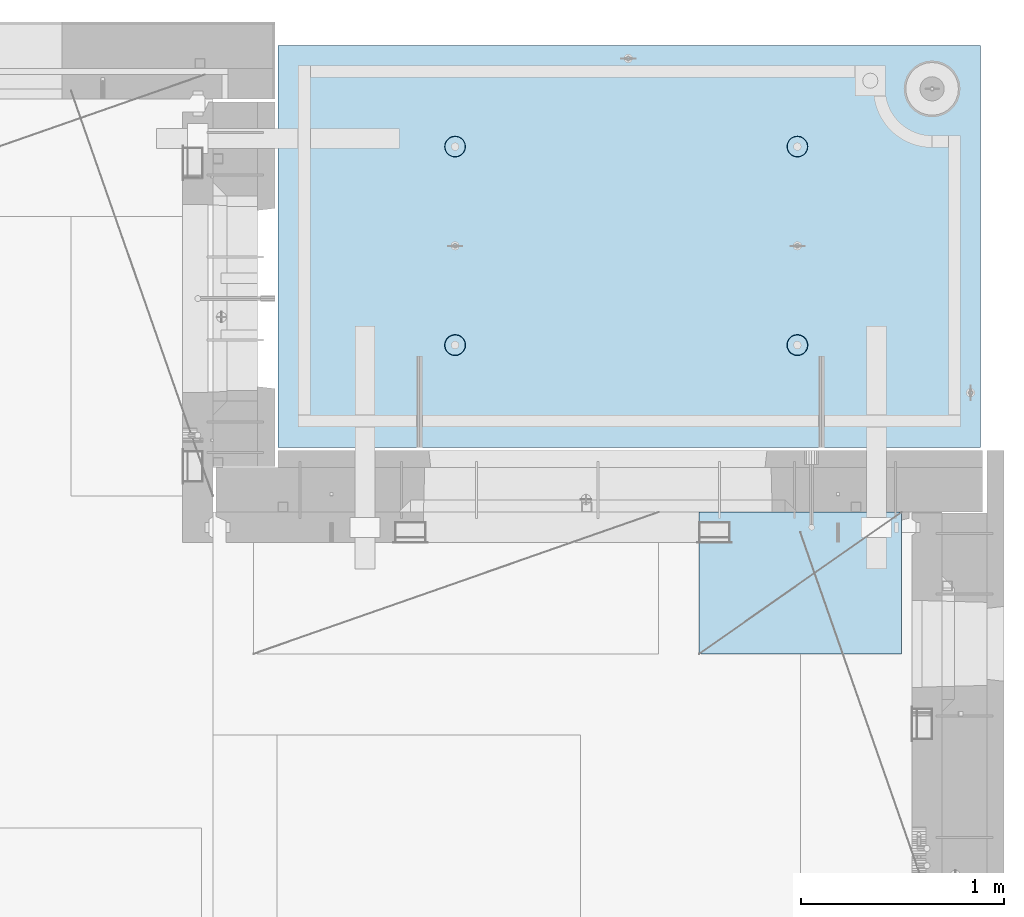
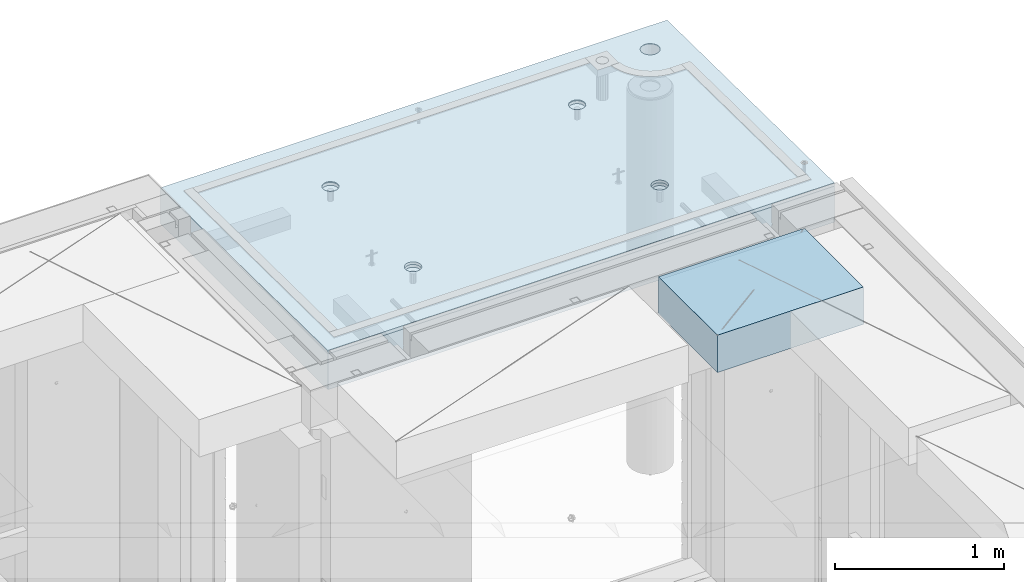
# One storey, part 212 of 350: 2 slabs, 1 plate, 2 elements without a shape of their own.
"""IFC2X3 building model written with IfcOpenShell, lengths in millimetres."""

from ifc_helpers import new_model, si_unit, frame, origin_with_axes, place, context, subcontext, project, spatial, faceted_brep, material, type_object, element, aggregate, save


model = new_model("IFC2X3")

# Units and contexts
model_context = context("Model", 3, precision=1e-05, world=origin_with_axes())
body_context = subcontext(model_context, "Body", "Model", "MODEL_VIEW")
ifc_project = project(units=[si_unit("LENGTHUNIT", "METRE", prefix="MILLI"), si_unit("AREAUNIT", "SQUARE_METRE"), si_unit("VOLUMEUNIT", "CUBIC_METRE"), si_unit("MASSUNIT", "GRAM", prefix="KILO"), si_unit("TIMEUNIT", "SECOND"), si_unit("PLANEANGLEUNIT", "RADIAN"), si_unit("SOLIDANGLEUNIT", "STERADIAN"), si_unit("THERMODYNAMICTEMPERATUREUNIT", "DEGREE_CELSIUS"), si_unit("LUMINOUSINTENSITYUNIT", "LUMEN")], contexts=[model_context])

# Site, building, storey
site_placement = place(None, origin_with_axes())
site = spatial("IfcSite", under=ifc_project, at=site_placement, CompositionType="ELEMENT")
building_placement = place(site_placement, origin_with_axes())
building = spatial("IfcBuilding", under=site, at=building_placement, CompositionType="ELEMENT")
storey_placement = place(building_placement, origin_with_axes())
storey = spatial("IfcBuildingStorey", under=building, at=storey_placement, Name="2", CompositionType="ELEMENT", Elevation=0.0)

# Assembly, slabs
assembly_1_placement = place(storey_placement, origin_with_axes())
assembly_1 = element("IfcElementAssembly", 1, at=assembly_1_placement, inside=storey, AssemblyPlace="NOTDEFINED", PredefinedType="REINFORCEMENT_UNIT")
ifc_material_1 = material(Name="CONCRETE/C35/45")
slab_type_1 = type_object("IfcSlabType", PredefinedType="NOTDEFINED")
slab_1_placement = place(assembly_1_placement, frame((31779.9998568133, 20899.9965573523, 87717.5), z_axis=(0.0, 1.0, 0.0), x_axis=(1.0, 0.0, 0.0)))
slab_1 = element("IfcSlab", 2, at=slab_1_placement, type_object=slab_type_1, material=ifc_material_1, PredefinedType="FLOOR", context=body_context, shape_type="Brep", body=[
    faceted_brep([(3287.06232936882, 9.55874156874779, 1751.46731182328), (3287.06232936882, 12.4999999999563, 1751.46731182328), (3278.5399580536, 12.4999999999563, 1734.74121634823), (3278.5399580536, 9.3480858430994, 1734.74121634823), (3265.26605352866, 12.4999999999563, 1721.46731182328), (3265.26605352866, 9.18090851265879, 1721.46731182328), (3248.5399580536, 12.4999999999563, 1712.94494050807), (3248.5399580536, 9.07357405936637, 1712.94494050807), (3229.99893839111, 12.4999999999563, 1710.00833148578), (3229.99893839111, 9.03658912732499, 1710.00833148578), (3211.45791872861, 12.4999999999563, 1712.94494050807), (3211.45791872861, 9.07357405936637, 1712.94494050807), (3194.73182325356, 12.4999999999563, 1721.46731182328), (3194.73182325356, 9.18090851267334, 1721.46731182328), (3181.45791872861, 12.4999999999563, 1734.74121634823), (3181.45791872861, 9.3480858430994, 1734.74121634823), (3172.9355474134, 12.4999999999563, 1751.46731182328), (3172.9355474134, 9.55874156874779, 1751.46731182328), (3169.99893839111, 12.4999999999563, 1770.00833148578), (3169.99893839111, 9.79225523948844, 1770.00833148578), (3172.9355474134, 12.4999999999563, 1788.54935114827), (3172.9355474134, 10.0257689102291, 1788.54935114827), (3181.45791872861, 12.4999999999563, 1805.27544662332), (3181.45791872861, 10.236424635892, 1805.27544662332), (3194.73182325356, 12.4999999999563, 1818.54935114827), (3194.73182325356, 10.4036019663181, 1818.54935114827), (3211.45791872861, 12.4999999999563, 1827.07172246349), (3211.45791872861, 10.5109364196105, 1827.07172246349), (3229.99893839111, 12.4999999999563, 1830.00833148578), (3229.99893839111, 10.5479213516664, 1830.00833148578), (3248.5399580536, 12.4999999999563, 1827.07172246349), (3248.5399580536, 10.5109364196105, 1827.07172246349), (3265.26605352866, 12.4999999999563, 1818.54935114827), (3265.26605352866, 10.4036019663181, 1818.54935114827), (3278.5399580536, 12.4999999999563, 1805.27544662332), (3278.5399580536, 10.2364246358775, 1805.27544662332), (3287.06232936882, 12.4999999999563, 1788.54935114827), (3287.06232936882, 10.0257689102291, 1788.54935114827), (3289.99893839111, 12.4999999999563, 1770.00833148578), (3289.99893839111, 9.79225523948844, 1770.00833148578), (7.41420080885291e-08, 12.4999999999927, 0.0), (-7.41420080885291e-08, -12.5, -3.63797880709171e-12), (0.0, 12.5, 1985.00366210938), (3470.0, 12.5, 0.0), (3470.00000000004, 12.4999999999563, 1985.00366210935), (3470.0, -12.5, 0.0), (2614.71871715545, -5.93617388149141, 521.168755308547), (2613.67503600632, 12.4999999999709, 520.829642746605), (2616.18047624359, 12.4999999999709, 505.010915653602), (2617.28998057371, -6.13967274603783, 505.010915653602), (2607.28293696061, -5.7526757610467, 535.738532951145), (2606.40396524136, 12.4999999999709, 535.099922616191), (2595.7125242481, -5.60710538028798, 547.296842506817), (2595.0790070157, 12.4999999999709, 546.424880841845), (2581.14006820649, -5.51366887726181, 554.715714533479), (2580.80872714612, 12.4999999999709, 553.695951606805), (2564.99000005311, -5.48147745869937, 557.271717883286), (2564.99000005311, 12.4999999999709, 556.201391844079), (2548.83993189974, -5.51366887726181, 554.715714533479), (2549.17127296011, 12.4999999999709, 553.695951606805), (2534.26747585813, -5.60710538028798, 547.296842506817), (2534.90099309052, 12.4999999999709, 546.424880841845), (2522.69706314561, -5.75267576103215, 535.738532951145), (2523.57603486487, 12.4999999999709, 535.099922616191), (2515.26128295077, -5.93617388147686, 521.168755308547), (2516.30496409991, 12.4999999999709, 520.829642746605), (2512.69001953251, -6.13967274603783, 505.010915653602), (2513.79952386263, 12.4999999999709, 505.010915653602), (2515.23823726424, -6.34326591769059, 488.84558800119), (2516.30496409991, 12.4999999999709, 489.192188560599), (2522.65977443627, -6.52701093736687, 474.256206522903), (2523.57603486487, 12.4999999999709, 474.921908691009), (2534.2301871423, -6.67288650246337, 462.673665286093), (2534.90099309052, 12.4999999999709, 463.596950465359), (2548.81688620273, -6.76656990486663, 455.235189411429), (2549.17127296011, 12.4999999999709, 456.325879700398), (2564.99000005311, -6.79885563062271, 452.67169805654), (2564.99000005311, 12.4999999999709, 453.820439463125), (2581.16311390349, -6.76656990486663, 455.235189411429), (2580.80872714612, 12.4999999999709, 456.325879700398), (2595.74981296392, -6.67288650246337, 462.673665286093), (2595.07900701571, 12.4999999999709, 463.596950465359), (2607.32022566996, -6.52701093736687, 474.256206522903), (2606.40396524136, 12.4999999999709, 474.921908691009), (2614.74176284199, -6.34326591769059, 488.84558800119), (2613.67503600632, 12.4999999999709, 489.192188560599), (924.718717121814, -5.93617388307757, 521.168755181017), (923.675035972585, 12.4999999999854, 520.829642619046), (926.180476209858, 12.4999999999854, 505.010915526043), (927.289980540074, -6.13967274762399, 505.010915526043), (917.282936926953, -5.75267576263286, 535.738532823641), (916.403965207624, 12.4999999999854, 535.099922488633), (905.712524214421, -5.60710538187413, 547.296842379335), (905.07900698197, 12.4999999999854, 546.424880714287), (891.140068172776, -5.51366887886252, 554.715714406011), (890.808727112384, 12.4999999999854, 553.695951479247), (874.990000019381, -5.48147746030008, 557.271717755822), (874.990000019381, 12.4999999999854, 556.20139171652), (858.839931865987, -5.51366887886252, 554.715714406011), (859.171272926378, 12.4999999999854, 553.695951479247), (844.267475824341, -5.60710538187413, 547.296842379335), (844.900993056792, 12.4999999999854, 546.424880714287), (832.697063111809, -5.75267576263286, 535.738532823641), (833.576034831138, 12.4999999999854, 535.099922488633), (825.261282916948, -5.93617388307757, 521.168755181017), (826.304964066177, 12.4999999999854, 520.829642619046), (822.690019498688, -6.13967274762399, 505.010915526043), (823.799523828904, 12.4999999999854, 505.010915526043), (825.238237230413, -6.34326591927675, 488.845587873602), (826.304964066174, 12.4999999999854, 489.19218843304), (832.659774402466, -6.52701093895303, 474.25620639529), (833.576034831141, 12.4999999999854, 474.921908563454), (844.230187108518, -6.67288650404953, 462.673665158458), (844.900993056788, 12.4999999999854, 463.5969503378), (858.816886168974, -6.76656990646734, 455.23518928378), (859.171272926378, 12.4999999999854, 456.32587957284), (874.990000019381, -6.79885563222342, 452.671697928887), (874.990000019381, 12.4999999999854, 453.820439335566), (891.163113869789, -6.76656990646734, 455.23518928378), (890.808727112384, 12.4999999999854, 456.32587957284), (905.749812930244, -6.67288650404953, 462.673665158458), (905.079006981974, 12.4999999999854, 463.5969503378), (917.320225636297, -6.52701093895303, 474.25620639529), (916.403965207621, 12.4999999999854, 474.921908563454), (924.741762808349, -6.34326591927675, 488.845587873602), (923.675035972588, 12.4999999999854, 489.19218843304), (924.02016693788, 6.4034111394576, 1500.93361352766), (923.67503595199, 12.4999999999854, 1500.82147367257), (926.18047618926, 12.4999999999854, 1485.00274657956), (926.555311256641, 6.20277086795249, 1485.00274657956), (916.688838773403, 6.58433162167785, 1515.29872631776), (916.403965187026, 12.4999999999854, 1515.09175354215), (905.280958178348, 6.7278571434581, 1526.69467377167), (905.079006961372, 12.4999999999854, 1526.4167117678), (890.913204613287, 6.81998112349538, 1534.0093312807), (890.808727091786, 12.4999999999854, 1533.68778253277), (874.989999998783, 6.85172034216521, 1536.52942989253), (874.989999998783, 12.4999999999854, 1536.19322277004), (859.066795384279, 6.81998112349538, 1534.0093312807), (859.17127290578, 12.4999999999854, 1533.68778253277), (844.699041819218, 6.7278571434581, 1526.69467377167), (844.900993036194, 12.4999999999854, 1526.4167117678), (833.291161224162, 6.58433162167785, 1515.29872631776), (833.57603481054, 12.4999999999854, 1515.09175354215), (825.959833059685, 6.4034111394576, 1500.93361352766), (826.304964045576, 12.4999999999854, 1500.82147367257), (823.424688740924, 6.20277086795249, 1485.00274657956), (823.799523808306, 12.4999999999854, 1485.00274657956), (825.93711110095, 6.00203761411831, 1469.06449681953), (826.304964045576, 12.4999999999854, 1469.18401948656), (833.254396317472, 5.82087370089721, 1454.68005557312), (833.57603481054, 12.4999999999854, 1454.91373961698), (844.66227690614, 5.67704728177341, 1443.26021682579), (844.90099303619, 12.4999999999854, 1443.58878139132), (859.044073415214, 5.58467987058975, 1435.9262308483), (859.17127290578, 12.4999999999854, 1436.31771062636), (874.989999998783, 5.55284766948898, 1433.39874941703), (874.989999998783, 12.4999999999854, 1433.81227038909), (890.935926582351, 5.58467987058975, 1435.9262308483), (890.808727091786, 12.4999999999854, 1436.31771062636), (905.317723091426, 5.67704728177341, 1443.26021682579), (905.079006961376, 12.4999999999854, 1443.58878139132), (916.725603680094, 5.82087370089721, 1454.68005557312), (916.403965187026, 12.4999999999854, 1454.91373961698), (924.042888896616, 6.00203761411831, 1469.06449681953), (923.67503595199, 12.4999999999854, 1469.18401948656), (2564.9899999698, 12.4999999999709, 1433.81227048016), (2564.9899999698, 5.55284767062403, 1433.39874950818), (2580.93592655335, 5.5846798717248, 1435.92623093945), (2580.8087270628, 12.4999999999709, 1436.31771071744), (2549.17127287679, 12.4999999999709, 1436.31771071744), (2549.04407338624, 5.5846798717248, 1435.92623093945), (2534.9009930072, 12.4999999999709, 1443.5887814824), (2534.66227687719, 5.67704728290846, 1443.26021691693), (2523.57603478155, 12.4999999999709, 1454.91373970805), (2523.25439628854, 5.82087370203226, 1454.68005566423), (2516.30496401659, 12.4999999999709, 1469.18401957764), (2515.93711107203, 6.00203761523881, 1469.06449691063), (2513.79952377931, 12.4999999999709, 1485.00274667064), (2513.424688712, 6.20277086908754, 1485.00274667064), (2516.30496401659, 12.4999999999709, 1500.82147376364), (2515.95983303076, 6.40341114059265, 1500.93361361872), (2523.57603478155, 12.4999999999709, 1515.09175363323), (2523.29116119523, 6.5843316228129, 1515.2987264088), (2534.90099300721, 12.4999999999709, 1526.41671185888), (2534.69904179027, 6.72785714459314, 1526.69467386269), (2549.17127287679, 12.4999999999709, 1533.68778262385), (2549.06679535531, 6.81998112463043, 1534.00933137171), (2564.9899999698, 12.4999999999709, 1536.19322286112), (2564.9899999698, 6.85172034330026, 1536.52942998354), (2580.8087270628, 12.4999999999709, 1533.68778262385), (2580.91320458428, 6.81998112463043, 1534.00933137171), (2595.07900693238, 12.4999999999709, 1526.41671185888), (2595.28095814932, 6.72785714459314, 1526.69467386269), (2606.40396515804, 12.4999999999709, 1515.09175363323), (2606.68883874436, 6.5843316228129, 1515.2987264088), (2613.675035923, 12.4999999999709, 1500.82147376364), (2614.02016690883, 6.40341114059265, 1500.93361361872), (2606.72560365105, 5.82087370203226, 1454.68005566423), (2595.3177230624, 5.67704728290846, 1443.26021691693), (2616.55531122759, 6.20277086908754, 1485.00274667064), (2614.04288886756, 6.00203761523881, 1469.06449691063), (2595.07900693239, 12.4999999999709, 1443.5887814824), (2606.40396515804, 12.4999999999709, 1454.91373970805), (2613.675035923, 12.4999999999709, 1469.18401957764), (2616.18047616028, 12.4999999999709, 1485.00274667064)], [[[0, 1, 2, 3]], [[3, 2, 4, 5]], [[5, 4, 6, 7]], [[7, 6, 8, 9]], [[9, 8, 10, 11]], [[11, 10, 12, 13]], [[13, 12, 14, 15]], [[15, 14, 16, 17]], [[17, 16, 18, 19]], [[19, 18, 20, 21]], [[21, 20, 22, 23]], [[23, 22, 24, 25]], [[25, 24, 26, 27]], [[27, 26, 28, 29]], [[29, 28, 30, 31]], [[31, 30, 32, 33]], [[33, 32, 34, 35]], [[35, 34, 36, 37]], [[37, 36, 38, 39]], [[39, 38, 1, 0]], [[40, 41, 42]], [[43, 44, 45]], [[40, 43, 45, 41]], [[46, 47, 48, 49]], [[50, 51, 47, 46]], [[52, 53, 51, 50]], [[54, 55, 53, 52]], [[56, 57, 55, 54]], [[58, 59, 57, 56]], [[59, 58, 60, 61]], [[61, 60, 62, 63]], [[63, 62, 64, 65]], [[65, 64, 66, 67]], [[67, 66, 68, 69]], [[69, 68, 70, 71]], [[71, 70, 72, 73]], [[73, 72, 74, 75]], [[75, 74, 76, 77]], [[78, 79, 77, 76]], [[80, 81, 79, 78]], [[82, 83, 81, 80]], [[84, 85, 83, 82]], [[49, 48, 85, 84]], [[86, 87, 88, 89]], [[90, 91, 87, 86]], [[92, 93, 91, 90]], [[94, 95, 93, 92]], [[96, 97, 95, 94]], [[98, 99, 97, 96]], [[99, 98, 100, 101]], [[101, 100, 102, 103]], [[103, 102, 104, 105]], [[105, 104, 106, 107]], [[107, 106, 108, 109]], [[109, 108, 110, 111]], [[111, 110, 112, 113]], [[113, 112, 114, 115]], [[115, 114, 116, 117]], [[118, 119, 117, 116]], [[120, 121, 119, 118]], [[122, 123, 121, 120]], [[124, 125, 123, 122]], [[89, 88, 125, 124]], [[126, 127, 128, 129]], [[130, 131, 127, 126]], [[132, 133, 131, 130]], [[134, 135, 133, 132]], [[136, 137, 135, 134]], [[138, 139, 137, 136]], [[140, 141, 139, 138]], [[142, 143, 141, 140]], [[143, 142, 144, 145]], [[145, 144, 146, 147]], [[147, 146, 148, 149]], [[149, 148, 150, 151]], [[151, 150, 152, 153]], [[153, 152, 154, 155]], [[155, 154, 156, 157]], [[157, 156, 158, 159]], [[159, 158, 160, 161]], [[162, 163, 161, 160]], [[164, 165, 163, 162]], [[129, 128, 165, 164]], [[166, 167, 168, 169]], [[170, 171, 167, 166]], [[172, 173, 171, 170]], [[174, 175, 173, 172]], [[176, 177, 175, 174]], [[178, 179, 177, 176]], [[180, 181, 179, 178]], [[182, 183, 181, 180]], [[183, 182, 184, 185]], [[185, 184, 186, 187]], [[187, 186, 188, 189]], [[189, 188, 190, 191]], [[191, 190, 192, 193]], [[193, 192, 194, 195]], [[195, 194, 196, 197]], [[44, 42, 41, 45], [3, 5, 7, 9, 11, 13, 15, 17, 19, 21, 23, 25, 27, 29, 31, 33, 35, 37, 39, 0], [198, 199, 168, 167, 171, 173, 175, 177, 179, 181, 183, 185, 187, 189, 191, 193, 195, 197, 200, 201], [162, 160, 158, 156, 154, 152, 150, 148, 146, 144, 142, 140, 138, 136, 134, 132, 130, 126, 129, 164], [122, 120, 118, 116, 114, 112, 110, 108, 106, 104, 102, 100, 98, 96, 94, 92, 90, 86, 89, 124], [82, 80, 78, 76, 74, 72, 70, 68, 66, 64, 62, 60, 58, 56, 54, 52, 50, 46, 49, 84]], [[169, 168, 199, 202]], [[198, 203, 202, 199]], [[201, 204, 203, 198]], [[200, 205, 204, 201]], [[197, 196, 205, 200]], [[43, 40, 42, 44], [34, 32, 30, 28, 26, 24, 22, 20, 18, 16, 14, 12, 10, 8, 6, 4, 2, 1, 38, 36], [194, 192, 190, 188, 186, 184, 182, 180, 178, 176, 174, 172, 170, 166, 169, 202, 203, 204, 205, 196], [131, 133, 135, 137, 139, 141, 143, 145, 147, 149, 151, 153, 155, 157, 159, 161, 163, 165, 128, 127], [91, 93, 95, 97, 99, 101, 103, 105, 107, 109, 111, 113, 115, 117, 119, 121, 123, 125, 88, 87], [51, 53, 55, 57, 59, 61, 63, 65, 67, 69, 71, 73, 75, 77, 79, 81, 83, 85, 48, 47]]]),
])
slab_type_2 = type_object("IfcSlabType", PredefinedType="NOTDEFINED")
slab_2_placement = place(assembly_1_placement, frame((31779.9998568132, 20899.9965573523, 87575.0), z_axis=(-1.19799915409591e-06, 0.999999999999282, 0.0), x_axis=(0.999999999999282, 1.19800000174933e-06, 0.0)))
slab_2 = element("IfcSlab", 3, at=slab_2_placement, type_object=slab_type_2, material=ifc_material_1, PredefinedType="FLOOR", context=body_context, shape_type="Brep", body=[
    faceted_brep([(2959.65048069304, -130.0, 1795.81551698422), (2959.65048069304, 130.000000000015, 1795.81551698422), (2951.52269537287, 130.000000000015, 1783.6488444481), (2951.52269537287, -130.0, 1783.6488444481), (2939.35761686434, 130.000000000015, 1775.51867349706), (2939.35761686434, -130.0, 1775.51867349706), (2925.00726809365, 130.000000000015, 1772.66274895821), (2925.00726809365, -130.0, 1772.66274895821), (2910.65635957491, 130.000000000015, 1775.51585945357), (2910.65635957491, -130.0, 1775.51585945357), (2898.48968703879, 130.000000000015, 1783.64364477374), (2898.48968703879, -130.0, 1783.64364477374), (2890.35951608775, 130.000000000015, 1795.80872328227), (2890.35951608775, -130.0, 1795.80872328227), (2887.5035915489, 130.000000000015, 1810.15907205296), (2887.5035915489, -130.0, 1810.15907205296), (2890.35670204427, 130.000000000015, 1824.5099805717), (2890.35670204427, -130.0, 1824.5099805717), (2898.48448736444, 130.000000000015, 1836.67665310783), (2898.48448736444, -130.0, 1836.67665310783), (2910.64956587296, 130.000000000015, 1844.80682405887), (2910.64956587296, -130.0, 1844.80682405887), (2924.99991464366, 130.000000000015, 1847.66274859772), (2924.99991464366, -130.0, 1847.66274859772), (2939.3508231624, 130.000000000015, 1844.80963810235), (2939.3508231624, -130.0, 1844.80963810235), (2951.51749569851, 130.000000000015, 1836.68185278219), (2951.51749569851, -130.0, 1836.68185278219), (2959.64766664955, 130.000000000015, 1824.51677427365), (2959.64766664955, -130.0, 1824.51677427365), (2962.50359118841, 130.000000000015, 1810.16642550296), (2962.50359118841, -130.0, 1810.16642550296), (3470.0, -130.0, -2.20097717829049e-09), (0.0, -130.0, -3.63797880709171e-12), (0.0, 130.0, -1.81898940354586e-12), (3470.0, 130.0, -2.20097717829049e-09), (3470.00048828125, -130.0, 1985.00366210938), (3470.00048828125, 130.0, 1985.00366210938), (0.000559809086553287, -130.0, 1985.00366210938), (0.000559809086553287, 130.0, 1985.00366210938), (890.443701616427, -110.0, 1437.44815412734), (904.382128602592, -110.0, 1444.55010256952), (915.443737652884, -110.0, 1455.61166772744), (922.54574140269, -110.0, 1469.55006653296), (924.992946242415, -110.0, 1485.00091139648), (922.545802711662, -110.0, 1500.4517659704), (915.443854269477, -110.0, 1514.39019295657), (904.382289111563, -110.0, 1525.45180200686), (890.44389030604, -110.0, 1532.55380575666), (874.993045442512, -110.0, 1535.00101059639), (859.5421908686, -110.0, 1532.55386706564), (845.603763882435, -110.0, 1525.45191862345), (834.542154832139, -110.0, 1514.39035346554), (827.440151082337, -110.0, 1500.45195466001), (824.992946242612, -110.0, 1485.00110979649), (827.440089773365, -110.0, 1469.55025522257), (834.542038215546, -110.0, 1455.61182823641), (845.603603373464, -110.0, 1444.55021918611), (859.542002178987, -110.0, 1437.44821543631), (874.992847042511, -110.0, 1435.00101059658), (923.678013579975, -130.0, 1500.81964109834), (926.183422432889, -130.0, 1485.00090903458), (916.406971127264, -130.0, 1515.08993539371), (905.082035370349, -130.0, 1526.41491608806), (890.811769926597, -130.0, 1533.68601516524), (874.993047804415, -130.0, 1536.19148678686), (859.174315740653, -130.0, 1533.68607793395), (844.904021445287, -130.0, 1526.41503548124), (833.579040750941, -130.0, 1515.09009972432), (826.307941673756, -130.0, 1500.81983428057), (823.802470052138, -130.0, 1485.00111215839), (826.307878905049, -130.0, 1469.18238009463), (833.578921357763, -130.0, 1454.91208579926), (844.903857114674, -130.0, 1443.58710510491), (859.17412255843, -130.0, 1436.31600602773), (874.992844680608, -130.0, 1433.81053440611), (890.811576744374, -130.0, 1436.31594325902), (905.081871039736, -130.0, 1443.58698571173), (916.406851734086, -130.0, 1454.91192146865), (923.677950811267, -130.0, 1469.1821869124), (890.441757333232, -110.0, 457.456323075745), (904.380184319398, -110.0, 464.558271517926), (915.44179336969, -110.0, 475.619836675844), (922.543797119495, -110.0, 489.558235481371), (924.991001959221, -110.0, 505.009080344891), (922.543858428468, -110.0, 520.459934918807), (915.441909986286, -110.0, 534.398361904972), (904.380344828369, -110.0, 545.459970955264), (890.441946022846, -110.0, 552.56197470507), (874.991101159318, -110.0, 555.009179544795), (859.540246585406, -110.0, 552.562036014042), (845.60181959924, -110.0, 545.460087571857), (834.540210548948, -110.0, 534.398522413943), (827.438206799143, -110.0, 520.46012360842), (824.991001959417, -110.0, 505.009278744892), (827.43814549017, -110.0, 489.558424170984), (834.540093932352, -110.0, 475.619997184815), (845.601659090269, -110.0, 464.558388134519), (859.540057895792, -110.0, 457.456384384717), (874.99090275932, -110.0, 455.009179544992), (923.676069296784, -130.0, 520.827810046754), (926.181478149694, -130.0, 505.009077982988), (916.405026844073, -130.0, 535.098104342116), (905.080091087159, -130.0, 546.423085036466), (890.809825643402, -130.0, 553.694184113647), (874.991103521224, -130.0, 556.199655735272), (859.172371457458, -130.0, 553.694246882354), (844.902077162096, -130.0, 546.423204429644), (833.57709646775, -130.0, 535.098268672729), (826.305997390566, -130.0, 520.828003228977), (823.800525768944, -130.0, 505.009281106795), (826.305934621854, -130.0, 489.190549043033), (833.576977074568, -130.0, 474.920254747667), (844.901912831479, -130.0, 463.595274053321), (859.172178275239, -130.0, 456.32417497614), (874.990900397414, -130.0, 453.818703354518), (890.809632461183, -130.0, 456.324112207432), (905.079926756542, -130.0, 463.595154660143), (916.404907450891, -130.0, 474.920090417054), (923.676006528072, -130.0, 489.19035586081), (2580.44175736364, -110.0, 457.452970243303), (2594.3801843498, -110.0, 464.554918685484), (2605.4417934001, -110.0, 475.616483843402), (2612.54379714991, -110.0, 489.554882648928), (2614.99100198962, -110.0, 505.005727512449), (2612.54385845887, -110.0, 520.456582086365), (2605.44191001669, -110.0, 534.39500907253), (2594.38034485878, -110.0, 545.456618122822), (2580.44194605325, -110.0, 552.558621872628), (2564.99110118972, -110.0, 555.005826712353), (2549.54024661581, -110.0, 552.5586831816), (2535.60181962965, -110.0, 545.456734739415), (2524.54021057935, -110.0, 534.395169581501), (2517.43820682954, -110.0, 520.456770775978), (2514.99100198982, -110.0, 505.00592591245), (2517.43814552058, -110.0, 489.555071338542), (2524.54009396276, -110.0, 475.616644352373), (2535.60165912067, -110.0, 464.555035302077), (2549.5400579262, -110.0, 457.453031552275), (2564.99090278973, -110.0, 455.00582671255), (2613.67606932719, -130.0, 520.824457214312), (2616.1814781801, -130.0, 505.005725150546), (2606.40502687448, -130.0, 535.094751509674), (2595.08009111756, -130.0, 546.419732204024), (2580.80982567381, -130.0, 553.690831281205), (2564.99110355163, -130.0, 556.19630290283), (2549.17237148786, -130.0, 553.690894049912), (2534.9020771925, -130.0, 546.419851597202), (2523.57709649815, -130.0, 535.094915840287), (2516.30599742097, -130.0, 520.824650396535), (2513.80052579935, -130.0, 505.005928274353), (2516.30593465226, -130.0, 489.187196210591), (2523.57697710497, -130.0, 474.916901915225), (2534.90191286189, -130.0, 463.591921220879), (2549.17217830564, -130.0, 456.320822143698), (2564.99090042782, -130.0, 453.815350522076), (2580.80963249159, -130.0, 456.32075937499), (2595.07992678695, -130.0, 463.591801827701), (2606.4049074813, -130.0, 474.916737584612), (2613.67600655848, -130.0, 489.187003028368), (2580.44370158411, -110.0, 1437.44480125841), (2594.38212857028, -110.0, 1444.5467497006), (2605.44373762057, -110.0, 1455.60831485851), (2612.54574137038, -110.0, 1469.54671366404), (2614.9929462101, -110.0, 1484.99755852756), (2612.54580267935, -110.0, 1500.44841310148), (2605.44385423717, -110.0, 1514.38684008764), (2594.38228907925, -110.0, 1525.44844913793), (2580.44389027373, -110.0, 1532.55045288774), (2564.9930454102, -110.0, 1534.99765772746), (2549.54219083629, -110.0, 1532.55051419671), (2535.60376385012, -110.0, 1525.44856575453), (2524.54215479983, -110.0, 1514.38700059661), (2517.44015105002, -110.0, 1500.44860179109), (2514.99294621029, -110.0, 1484.99775692756), (2517.44008974105, -110.0, 1469.54690235365), (2524.54203818323, -110.0, 1455.60847536748), (2535.60360334115, -110.0, 1444.54686631719), (2549.54200214667, -110.0, 1437.44486256739), (2564.9928470102, -110.0, 1434.99765772766), (2613.67801354766, -130.0, 1500.81628822942), (2616.18342240057, -130.0, 1484.99755616566), (2606.40697109495, -130.0, 1515.08658252479), (2595.08203533804, -130.0, 1526.41156321914), (2580.81176989429, -130.0, 1533.68266229632), (2564.9930477721, -130.0, 1536.18813391794), (2549.17431570834, -130.0, 1533.68272506502), (2534.90402141297, -130.0, 1526.41168261231), (2523.57904071863, -130.0, 1515.0867468554), (2516.30794164144, -130.0, 1500.81648141164), (2513.80247001983, -130.0, 1484.99775928947), (2516.30787887274, -130.0, 1469.1790272257), (2523.57892132545, -130.0, 1454.90873293034), (2534.90385708237, -130.0, 1443.58375223599), (2549.17412252611, -130.0, 1436.31265315881), (2564.99284464829, -130.0, 1433.80718153719), (2580.81157671207, -130.0, 1436.3125903901), (2595.08187100743, -130.0, 1443.58363284281), (2606.40685170178, -130.0, 1454.90856859972), (2613.67795077896, -130.0, 1469.17883404348), (3278.54339977372, -130.0, 1734.73471172154), (3265.26946891338, -130.0, 1721.46083353204), (3248.54335652997, -130.0, 1712.93849540142), (3230.00233104128, -130.0, 1710.00192316452), (3211.46131720506, -130.0, 1712.93856897219), (3194.73523863843, -130.0, 1721.46097347196), (3181.46136044892, -130.0, 1734.73490433231), (3172.9390223183, -130.0, 1751.46101671571), (3170.0024500814, -130.0, 1770.0020422044), (3172.93909588907, -130.0, 1788.54305604063), (3181.46150038884, -130.0, 1805.26913460726), (3194.73543124919, -130.0, 1818.54301279676), (3211.46154363259, -130.0, 1827.06535092738), (3230.00256912128, -130.0, 1830.00192316428), (3248.54358295751, -130.0, 1827.06527735662), (3265.26966152415, -130.0, 1818.54287285685), (3278.54353971364, -130.0, 1805.2689419965), (3287.06587784427, -130.0, 1788.5428296131), (3290.00245008117, -130.0, 1770.0018041244), (3287.0658042735, -130.0, 1751.46079028817), (3278.54353971364, 130.0, 1805.2689419965), (3287.06587784427, 130.0, 1788.5428296131), (3265.26966152415, 130.0, 1818.54287285685), (3248.54358295751, 130.0, 1827.06527735662), (3230.00256912128, 130.0, 1830.00192316428), (3211.46154363259, 130.0, 1827.06535092738), (3194.73543124919, 130.0, 1818.54301279676), (3181.46150038884, 130.0, 1805.26913460726), (3172.93909588907, 130.0, 1788.54305604063), (3170.0024500814, 130.0, 1770.0020422044), (3172.9390223183, 130.0, 1751.46101671571), (3181.46136044892, 130.0, 1734.73490433231), (3194.73523863843, 130.0, 1721.46097347196), (3211.46131720506, 130.0, 1712.93856897219), (3230.00233104128, 130.0, 1710.00192316452), (3248.54335652997, 130.0, 1712.93849540142), (3265.26946891338, 130.0, 1721.46083353204), (3278.54339977372, 130.0, 1734.73471172154), (3287.0658042735, 130.0, 1751.46079028817), (3290.00245008117, 130.0, 1770.0018041244)], [[[0, 1, 2, 3]], [[3, 2, 4, 5]], [[5, 4, 6, 7]], [[7, 6, 8, 9]], [[9, 8, 10, 11]], [[11, 10, 12, 13]], [[13, 12, 14, 15]], [[15, 14, 16, 17]], [[17, 16, 18, 19]], [[19, 18, 20, 21]], [[21, 20, 22, 23]], [[23, 22, 24, 25]], [[25, 24, 26, 27]], [[27, 26, 28, 29]], [[29, 28, 30, 31]], [[31, 30, 1, 0]], [[32, 33, 34, 35]], [[36, 32, 35, 37]], [[38, 36, 37, 39]], [[33, 38, 39, 34]], [[40, 41, 42, 43, 44, 45, 46, 47, 48, 49, 50, 51, 52, 53, 54, 55, 56, 57, 58, 59]], [[60, 45, 44, 61]], [[62, 46, 45, 60]], [[63, 47, 46, 62]], [[64, 48, 47, 63]], [[65, 49, 48, 64]], [[66, 50, 49, 65]], [[67, 51, 50, 66]], [[68, 52, 51, 67]], [[69, 53, 52, 68]], [[70, 54, 53, 69]], [[71, 55, 54, 70]], [[72, 56, 55, 71]], [[73, 57, 56, 72]], [[74, 58, 57, 73]], [[75, 59, 58, 74]], [[76, 40, 59, 75]], [[77, 41, 40, 76]], [[78, 42, 41, 77]], [[79, 43, 42, 78]], [[61, 44, 43, 79]], [[80, 81, 82, 83, 84, 85, 86, 87, 88, 89, 90, 91, 92, 93, 94, 95, 96, 97, 98, 99]], [[100, 85, 84, 101]], [[102, 86, 85, 100]], [[103, 87, 86, 102]], [[104, 88, 87, 103]], [[105, 89, 88, 104]], [[106, 90, 89, 105]], [[107, 91, 90, 106]], [[108, 92, 91, 107]], [[109, 93, 92, 108]], [[110, 94, 93, 109]], [[111, 95, 94, 110]], [[112, 96, 95, 111]], [[113, 97, 96, 112]], [[114, 98, 97, 113]], [[115, 99, 98, 114]], [[116, 80, 99, 115]], [[117, 81, 80, 116]], [[118, 82, 81, 117]], [[119, 83, 82, 118]], [[101, 84, 83, 119]], [[120, 121, 122, 123, 124, 125, 126, 127, 128, 129, 130, 131, 132, 133, 134, 135, 136, 137, 138, 139]], [[140, 125, 124, 141]], [[142, 126, 125, 140]], [[143, 127, 126, 142]], [[144, 128, 127, 143]], [[145, 129, 128, 144]], [[146, 130, 129, 145]], [[147, 131, 130, 146]], [[148, 132, 131, 147]], [[149, 133, 132, 148]], [[150, 134, 133, 149]], [[151, 135, 134, 150]], [[152, 136, 135, 151]], [[153, 137, 136, 152]], [[154, 138, 137, 153]], [[155, 139, 138, 154]], [[156, 120, 139, 155]], [[157, 121, 120, 156]], [[158, 122, 121, 157]], [[159, 123, 122, 158]], [[141, 124, 123, 159]], [[160, 161, 162, 163, 164, 165, 166, 167, 168, 169, 170, 171, 172, 173, 174, 175, 176, 177, 178, 179]], [[180, 165, 164, 181]], [[182, 166, 165, 180]], [[183, 167, 166, 182]], [[184, 168, 167, 183]], [[185, 169, 168, 184]], [[186, 170, 169, 185]], [[187, 171, 170, 186]], [[188, 172, 171, 187]], [[189, 173, 172, 188]], [[190, 174, 173, 189]], [[191, 175, 174, 190]], [[192, 176, 175, 191]], [[193, 177, 176, 192]], [[194, 178, 177, 193]], [[195, 179, 178, 194]], [[196, 160, 179, 195]], [[197, 161, 160, 196]], [[198, 162, 161, 197]], [[199, 163, 162, 198]], [[181, 164, 163, 199]], [[32, 36, 38, 33], [3, 5, 7, 9, 11, 13, 15, 17, 19, 21, 23, 25, 27, 29, 31, 0], [198, 197, 196, 195, 194, 193, 192, 191, 190, 189, 188, 187, 186, 185, 184, 183, 182, 180, 181, 199], [158, 157, 156, 155, 154, 153, 152, 151, 150, 149, 148, 147, 146, 145, 144, 143, 142, 140, 141, 159], [118, 117, 116, 115, 114, 113, 112, 111, 110, 109, 108, 107, 106, 105, 104, 103, 102, 100, 101, 119], [78, 77, 76, 75, 74, 73, 72, 71, 70, 69, 68, 67, 66, 65, 64, 63, 62, 60, 61, 79], [200, 201, 202, 203, 204, 205, 206, 207, 208, 209, 210, 211, 212, 213, 214, 215, 216, 217, 218, 219]], [[216, 220, 221, 217]], [[215, 222, 220, 216]], [[214, 223, 222, 215]], [[213, 224, 223, 214]], [[212, 225, 224, 213]], [[211, 226, 225, 212]], [[210, 227, 226, 211]], [[209, 228, 227, 210]], [[208, 229, 228, 209]], [[207, 230, 229, 208]], [[206, 231, 230, 207]], [[205, 232, 231, 206]], [[204, 233, 232, 205]], [[203, 234, 233, 204]], [[202, 235, 234, 203]], [[201, 236, 235, 202]], [[200, 237, 236, 201]], [[219, 238, 237, 200]], [[218, 239, 238, 219]], [[217, 221, 239, 218]], [[37, 35, 34, 39], [26, 24, 22, 20, 18, 16, 14, 12, 10, 8, 6, 4, 2, 1, 30, 28], [220, 222, 223, 224, 225, 226, 227, 228, 229, 230, 231, 232, 233, 234, 235, 236, 237, 238, 239, 221]]]),
])
aggregate(assembly_1, [slab_1, slab_2])

# Assembly, plate
assembly_2_placement = place(storey_placement, origin_with_axes())
assembly_2 = element("IfcElementAssembly", 4, at=assembly_2_placement, inside=storey, Name="Steel Assembly", AssemblyPlace="NOTDEFINED", PredefinedType="NOTDEFINED")
ifc_material_2 = material()
plate_type = type_object("IfcPlateType", PredefinedType="NOTDEFINED")
plate_placement = place(assembly_2_placement, frame((34860.0, 20580.0000000707, 87595.3), z_axis=(0.0, -1.0, 0.0), x_axis=(-1.0, 3.00000001838171e-08, 0.0)))
plate = element("IfcPlate", 5, at=plate_placement, type_object=plate_type, material=ifc_material_2, Name="RE1_1/2", context=body_context, shape_type="Brep", body=[
    faceted_brep([(1.81898940354586e-12, -135.0, 1.81898940354586e-12), (0.0, -135.0, 699.999999999996), (0.0, 135.0, 699.999999999996), (1.81898940354586e-12, 135.0, 1.81898940354586e-12), (999.99951171875, -135.0, 700.0), (999.99951171875, 135.0, 700.0), (1000.0, -135.0, 0.0), (1000.0, 135.0, 0.0)], [[[0, 1, 2, 3]], [[1, 4, 5, 2]], [[4, 6, 7, 5]], [[6, 0, 3, 7]], [[5, 7, 3, 2]], [[6, 4, 1, 0]]]),
])
aggregate(assembly_2, [plate])

save(model, "model.ifc")
